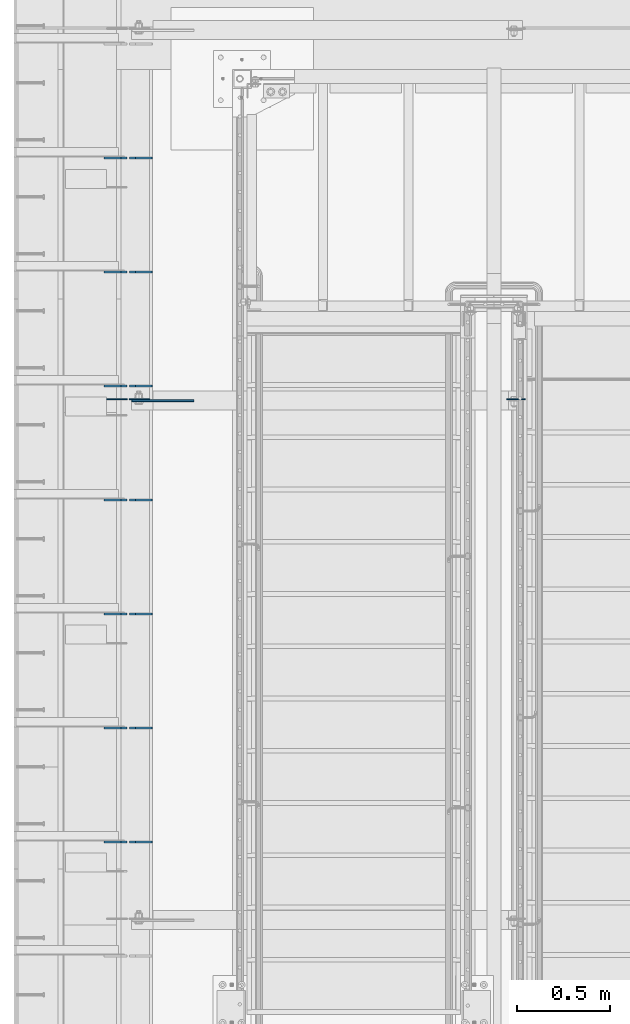
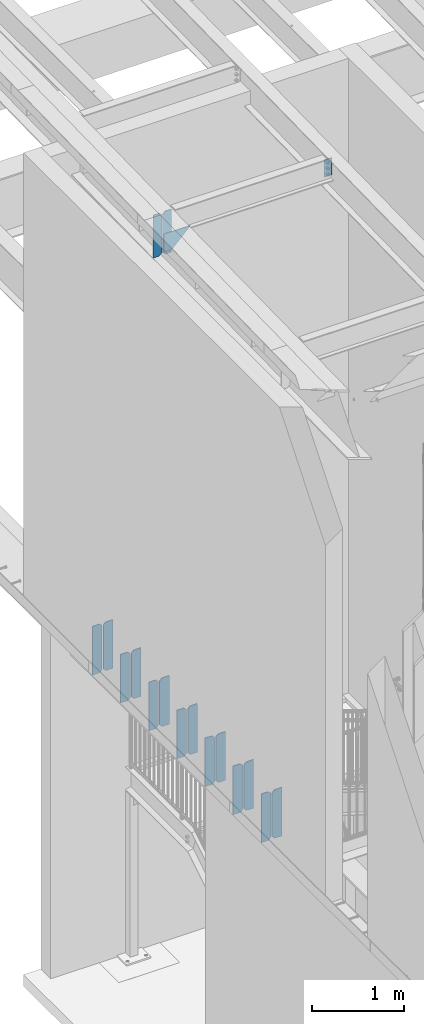
# One storey, part 1512 of 1763: 18 plates, 4 elements without a shape of their own.
"""IFC2X3 building model written with IfcOpenShell, lengths in millimetres."""

from ifc_helpers import new_model, si_unit, frame, origin_with_axes, place, context, subcontext, project, spatial, faceted_brep, material, type_object, element, aggregate, save


model = new_model("IFC2X3")

# Units and contexts
model_context = context("Model", 3, precision=1e-05, world=origin_with_axes())
body_context = subcontext(model_context, "Body", "Model", "MODEL_VIEW")
ifc_project = project(units=[si_unit("LENGTHUNIT", "METRE", prefix="MILLI"), si_unit("AREAUNIT", "SQUARE_METRE"), si_unit("VOLUMEUNIT", "CUBIC_METRE"), si_unit("MASSUNIT", "GRAM", prefix="KILO"), si_unit("TIMEUNIT", "SECOND"), si_unit("PLANEANGLEUNIT", "RADIAN"), si_unit("SOLIDANGLEUNIT", "STERADIAN"), si_unit("THERMODYNAMICTEMPERATUREUNIT", "DEGREE_CELSIUS"), si_unit("LUMINOUSINTENSITYUNIT", "LUMEN")], contexts=[model_context])

# Site, building, storey
site_placement = place(None, origin_with_axes())
site = spatial("IfcSite", under=ifc_project, at=site_placement, CompositionType="ELEMENT")
building_placement = place(site_placement, origin_with_axes())
building = spatial("IfcBuilding", under=site, at=building_placement, Name="Undefined", CompositionType="ELEMENT")
storey_placement = place(building_placement, origin_with_axes())
storey = spatial("IfcBuildingStorey", under=building, at=storey_placement, Name="Undefined", CompositionType="ELEMENT", Elevation=0.0)

# Assembly, plates
assembly_1_placement = place(storey_placement, origin_with_axes())
assembly_1 = element("IfcElementAssembly", 1, at=assembly_1_placement, inside=storey, Name="BEAM", AssemblyPlace="NOTDEFINED", PredefinedType="RIGID_FRAME")
ifc_material = material(Name="STEEL/A36")
plate_type_1 = type_object("IfcPlateType", PredefinedType="NOTDEFINED")
plate_1_placement = place(assembly_1_placement, frame((-87246.8497736984, 33218.4375, 4525.9625), z_axis=(0.0, 0.0, 1.0), x_axis=(-1.0, 0.0, 0.0)))
plate_1 = element("IfcPlate", 2, at=plate_1_placement, type_object=plate_type_1, material=ifc_material, Name="PLATE", context=body_context, shape_type="Brep", body=[
    faceted_brep([(0.0, -4.76249999999982, 0.0), (0.0, -4.76250000000073, 644.525024414062), (0.0, 4.76250000000073, 644.525024414062), (0.0, 4.76249999999982, 0.0), (89.6937484741211, -4.76250000000073, 644.525024414062), (89.6937484741211, 4.76250000000073, 644.525024414062), (121.443748474121, -4.76250000000073, 612.775024414062), (121.443748474121, 4.76250000000073, 612.775024414062), (121.443748474121, -4.76250000000073, 31.75), (121.443748474121, 4.76250000000073, 31.75), (89.6937484741211, -4.76249999999709, 0.0), (89.6937484741211, 4.76249999999709, 0.0)], [[[0, 1, 2, 3]], [[1, 4, 5, 2]], [[4, 6, 7, 5]], [[6, 8, 9, 7]], [[8, 10, 11, 9]], [[10, 0, 3, 11]], [[5, 7, 9, 11, 3, 2]], [[10, 8, 6, 4, 1, 0]]]),
])
plate_2_placement = place(assembly_1_placement, frame((-87382.5810236984, 33218.4375, 4525.9625), z_axis=(0.0, 0.0, 1.0), x_axis=(-1.0, 0.0, 0.0)))
plate_2 = element("IfcPlate", 3, at=plate_2_placement, type_object=plate_type_1, material=ifc_material, Name="PLATE", context=body_context, shape_type="Brep", body=[
    faceted_brep([(0.0, -4.76250000000073, 31.75), (0.0, -4.76250000000073, 612.775024414062), (0.0, 4.76250000000073, 612.775024414062), (0.0, 4.76250000000073, 31.75), (31.75, -4.76250000000073, 644.525024414062), (31.75, 4.76250000000073, 644.525024414062), (121.443748474121, -4.76250000000073, 644.525024414062), (121.443748474121, 4.76250000000073, 644.525024414062), (121.443748474121, -4.76250000000073, 0.0), (121.443748474121, 4.76250000000073, 0.0), (31.75, -4.76250000000073, 0.0), (31.75, 4.76250000000073, 0.0)], [[[0, 1, 2, 3]], [[1, 4, 5, 2]], [[4, 6, 7, 5]], [[6, 8, 9, 7]], [[8, 10, 11, 9]], [[10, 0, 3, 11]], [[5, 7, 9, 11, 3, 2]], [[10, 8, 6, 4, 1, 0]]]),
])
plate_3_placement = place(assembly_1_placement, frame((-87246.8497736984, 33828.0375, 4525.9625), z_axis=(0.0, 0.0, 1.0), x_axis=(-1.0, 0.0, 0.0)))
plate_3 = element("IfcPlate", 4, at=plate_3_placement, type_object=plate_type_1, material=ifc_material, Name="PLATE", context=body_context, shape_type="Brep", body=[
    faceted_brep([(0.0, -4.76249999999982, 0.0), (0.0, -4.76250000000073, 644.525024414062), (0.0, 4.76250000000073, 644.525024414062), (0.0, 4.76249999999982, 0.0), (89.6937484741211, -4.76250000000073, 644.525024414062), (89.6937484741211, 4.76250000000073, 644.525024414062), (121.443748474121, -4.76250000000073, 612.775024414062), (121.443748474121, 4.76250000000073, 612.775024414062), (121.443748474121, -4.76250000000073, 31.75), (121.443748474121, 4.76250000000073, 31.75), (89.6937484741211, -4.76249999999709, 0.0), (89.6937484741211, 4.76249999999709, 0.0)], [[[0, 1, 2, 3]], [[1, 4, 5, 2]], [[4, 6, 7, 5]], [[6, 8, 9, 7]], [[8, 10, 11, 9]], [[10, 0, 3, 11]], [[5, 7, 9, 11, 3, 2]], [[10, 8, 6, 4, 1, 0]]]),
])
plate_4_placement = place(assembly_1_placement, frame((-87382.5810236984, 33828.0375, 4525.9625), z_axis=(0.0, 0.0, 1.0), x_axis=(-1.0, 0.0, 0.0)))
plate_4 = element("IfcPlate", 5, at=plate_4_placement, type_object=plate_type_1, material=ifc_material, Name="PLATE", context=body_context, shape_type="Brep", body=[
    faceted_brep([(0.0, -4.76250000000073, 31.75), (0.0, -4.76250000000073, 612.775024414062), (0.0, 4.76250000000073, 612.775024414062), (0.0, 4.76250000000073, 31.75), (31.75, -4.76250000000073, 644.525024414062), (31.75, 4.76250000000073, 644.525024414062), (121.443748474121, -4.76250000000073, 644.525024414062), (121.443748474121, 4.76250000000073, 644.525024414062), (121.443748474121, -4.76250000000073, 0.0), (121.443748474121, 4.76250000000073, 0.0), (31.75, -4.76250000000073, 0.0), (31.75, 4.76250000000073, 0.0)], [[[0, 1, 2, 3]], [[1, 4, 5, 2]], [[4, 6, 7, 5]], [[6, 8, 9, 7]], [[8, 10, 11, 9]], [[10, 0, 3, 11]], [[5, 7, 9, 11, 3, 2]], [[10, 8, 6, 4, 1, 0]]]),
])
plate_5_placement = place(assembly_1_placement, frame((-87246.8497736984, 34437.6375, 4525.9625), z_axis=(0.0, 0.0, 1.0), x_axis=(-1.0, 0.0, 0.0)))
plate_5 = element("IfcPlate", 6, at=plate_5_placement, type_object=plate_type_1, material=ifc_material, Name="PLATE", context=body_context, shape_type="Brep", body=[
    faceted_brep([(0.0, -4.76249999999982, 0.0), (0.0, -4.76250000000073, 644.525024414062), (0.0, 4.76250000000073, 644.525024414062), (0.0, 4.76249999999982, 0.0), (89.6937484741211, -4.76250000000073, 644.525024414062), (89.6937484741211, 4.76250000000073, 644.525024414062), (121.443748474121, -4.76250000000073, 612.775024414062), (121.443748474121, 4.76250000000073, 612.775024414062), (121.443748474121, -4.76250000000073, 31.75), (121.443748474121, 4.76250000000073, 31.75), (89.6937484741211, -4.76249999999709, 0.0), (89.6937484741211, 4.76249999999709, 0.0)], [[[0, 1, 2, 3]], [[1, 4, 5, 2]], [[4, 6, 7, 5]], [[6, 8, 9, 7]], [[8, 10, 11, 9]], [[10, 0, 3, 11]], [[5, 7, 9, 11, 3, 2]], [[10, 8, 6, 4, 1, 0]]]),
])
plate_6_placement = place(assembly_1_placement, frame((-87382.5810236984, 34437.6375, 4525.9625), z_axis=(0.0, 0.0, 1.0), x_axis=(-1.0, 0.0, 0.0)))
plate_6 = element("IfcPlate", 7, at=plate_6_placement, type_object=plate_type_1, material=ifc_material, Name="PLATE", context=body_context, shape_type="Brep", body=[
    faceted_brep([(0.0, -4.76250000000073, 31.75), (0.0, -4.76250000000073, 612.775024414062), (0.0, 4.76250000000073, 612.775024414062), (0.0, 4.76250000000073, 31.75), (31.75, -4.76250000000073, 644.525024414062), (31.75, 4.76250000000073, 644.525024414062), (121.443748474121, -4.76250000000073, 644.525024414062), (121.443748474121, 4.76250000000073, 644.525024414062), (121.443748474121, -4.76250000000073, 0.0), (121.443748474121, 4.76250000000073, 0.0), (31.75, -4.76250000000073, 0.0), (31.75, 4.76250000000073, 0.0)], [[[0, 1, 2, 3]], [[1, 4, 5, 2]], [[4, 6, 7, 5]], [[6, 8, 9, 7]], [[8, 10, 11, 9]], [[10, 0, 3, 11]], [[5, 7, 9, 11, 3, 2]], [[10, 8, 6, 4, 1, 0]]]),
])
plate_7_placement = place(assembly_1_placement, frame((-87246.8497736984, 35047.2375, 4525.9625), z_axis=(0.0, 0.0, 1.0), x_axis=(-1.0, 0.0, 0.0)))
plate_7 = element("IfcPlate", 8, at=plate_7_placement, type_object=plate_type_1, material=ifc_material, Name="PLATE", context=body_context, shape_type="Brep", body=[
    faceted_brep([(0.0, -4.76249999999982, 0.0), (0.0, -4.76250000000073, 644.525024414062), (0.0, 4.76250000000073, 644.525024414062), (0.0, 4.76249999999982, 0.0), (89.6937484741211, -4.76250000000073, 644.525024414062), (89.6937484741211, 4.76250000000073, 644.525024414062), (121.443748474121, -4.76250000000073, 612.775024414062), (121.443748474121, 4.76250000000073, 612.775024414062), (121.443748474121, -4.76250000000073, 31.75), (121.443748474121, 4.76250000000073, 31.75), (89.6937484741211, -4.76249999999709, 0.0), (89.6937484741211, 4.76249999999709, 0.0)], [[[0, 1, 2, 3]], [[1, 4, 5, 2]], [[4, 6, 7, 5]], [[6, 8, 9, 7]], [[8, 10, 11, 9]], [[10, 0, 3, 11]], [[5, 7, 9, 11, 3, 2]], [[10, 8, 6, 4, 1, 0]]]),
])
plate_8_placement = place(assembly_1_placement, frame((-87382.5810236984, 35047.2375, 4525.9625), z_axis=(0.0, 0.0, 1.0), x_axis=(-1.0, 0.0, 0.0)))
plate_8 = element("IfcPlate", 9, at=plate_8_placement, type_object=plate_type_1, material=ifc_material, Name="PLATE", context=body_context, shape_type="Brep", body=[
    faceted_brep([(0.0, -4.76250000000073, 31.75), (0.0, -4.76250000000073, 612.775024414062), (0.0, 4.76250000000073, 612.775024414062), (0.0, 4.76250000000073, 31.75), (31.75, -4.76250000000073, 644.525024414062), (31.75, 4.76250000000073, 644.525024414062), (121.443748474121, -4.76250000000073, 644.525024414062), (121.443748474121, 4.76250000000073, 644.525024414062), (121.443748474121, -4.76250000000073, 0.0), (121.443748474121, 4.76250000000073, 0.0), (31.75, -4.76250000000073, 0.0), (31.75, 4.76250000000073, 0.0)], [[[0, 1, 2, 3]], [[1, 4, 5, 2]], [[4, 6, 7, 5]], [[6, 8, 9, 7]], [[8, 10, 11, 9]], [[10, 0, 3, 11]], [[5, 7, 9, 11, 3, 2]], [[10, 8, 6, 4, 1, 0]]]),
])
plate_9_placement = place(assembly_1_placement, frame((-87246.8497736984, 35656.8375, 4525.9625), z_axis=(0.0, 0.0, 1.0), x_axis=(-1.0, 0.0, 0.0)))
plate_9 = element("IfcPlate", 10, at=plate_9_placement, type_object=plate_type_1, material=ifc_material, Name="PLATE", context=body_context, shape_type="Brep", body=[
    faceted_brep([(0.0, -4.76249999999982, 0.0), (0.0, -4.76250000000073, 644.525024414062), (0.0, 4.76250000000073, 644.525024414062), (0.0, 4.76249999999982, 0.0), (89.6937484741211, -4.76250000000073, 644.525024414062), (89.6937484741211, 4.76250000000073, 644.525024414062), (121.443748474121, -4.76250000000073, 612.775024414062), (121.443748474121, 4.76250000000073, 612.775024414062), (121.443748474121, -4.76250000000073, 31.75), (121.443748474121, 4.76250000000073, 31.75), (89.6937484741211, -4.76249999999709, 0.0), (89.6937484741211, 4.76249999999709, 0.0)], [[[0, 1, 2, 3]], [[1, 4, 5, 2]], [[4, 6, 7, 5]], [[6, 8, 9, 7]], [[8, 10, 11, 9]], [[10, 0, 3, 11]], [[5, 7, 9, 11, 3, 2]], [[10, 8, 6, 4, 1, 0]]]),
])
plate_10_placement = place(assembly_1_placement, frame((-87382.5810236984, 35656.8375, 4525.9625), z_axis=(0.0, 0.0, 1.0), x_axis=(-1.0, 0.0, 0.0)))
plate_10 = element("IfcPlate", 11, at=plate_10_placement, type_object=plate_type_1, material=ifc_material, Name="PLATE", context=body_context, shape_type="Brep", body=[
    faceted_brep([(0.0, -4.76250000000073, 31.75), (0.0, -4.76250000000073, 612.775024414062), (0.0, 4.76250000000073, 612.775024414062), (0.0, 4.76250000000073, 31.75), (31.75, -4.76250000000073, 644.525024414062), (31.75, 4.76250000000073, 644.525024414062), (121.443748474121, -4.76250000000073, 644.525024414062), (121.443748474121, 4.76250000000073, 644.525024414062), (121.443748474121, -4.76250000000073, 0.0), (121.443748474121, 4.76250000000073, 0.0), (31.75, -4.76250000000073, 0.0), (31.75, 4.76250000000073, 0.0)], [[[0, 1, 2, 3]], [[1, 4, 5, 2]], [[4, 6, 7, 5]], [[6, 8, 9, 7]], [[8, 10, 11, 9]], [[10, 0, 3, 11]], [[5, 7, 9, 11, 3, 2]], [[10, 8, 6, 4, 1, 0]]]),
])
plate_11_placement = place(assembly_1_placement, frame((-87246.8497736984, 36266.4375, 4525.9625), z_axis=(0.0, 0.0, 1.0), x_axis=(-1.0, 0.0, 0.0)))
plate_11 = element("IfcPlate", 12, at=plate_11_placement, type_object=plate_type_1, material=ifc_material, Name="PLATE", context=body_context, shape_type="Brep", body=[
    faceted_brep([(0.0, -4.76249999999982, 0.0), (0.0, -4.76250000000073, 644.525024414062), (0.0, 4.76250000000073, 644.525024414062), (0.0, 4.76249999999982, 0.0), (89.6937484741211, -4.76250000000073, 644.525024414062), (89.6937484741211, 4.76250000000073, 644.525024414062), (121.443748474121, -4.76250000000073, 612.775024414062), (121.443748474121, 4.76250000000073, 612.775024414062), (121.443748474121, -4.76250000000073, 31.75), (121.443748474121, 4.76250000000073, 31.75), (89.6937484741211, -4.76249999999709, 0.0), (89.6937484741211, 4.76249999999709, 0.0)], [[[0, 1, 2, 3]], [[1, 4, 5, 2]], [[4, 6, 7, 5]], [[6, 8, 9, 7]], [[8, 10, 11, 9]], [[10, 0, 3, 11]], [[5, 7, 9, 11, 3, 2]], [[10, 8, 6, 4, 1, 0]]]),
])
plate_12_placement = place(assembly_1_placement, frame((-87382.5810236984, 36266.4375, 4525.9625), z_axis=(0.0, 0.0, 1.0), x_axis=(-1.0, 0.0, 0.0)))
plate_12 = element("IfcPlate", 13, at=plate_12_placement, type_object=plate_type_1, material=ifc_material, Name="PLATE", context=body_context, shape_type="Brep", body=[
    faceted_brep([(0.0, -4.76250000000073, 31.75), (0.0, -4.76250000000073, 612.775024414062), (0.0, 4.76250000000073, 612.775024414062), (0.0, 4.76250000000073, 31.75), (31.75, -4.76250000000073, 644.525024414062), (31.75, 4.76250000000073, 644.525024414062), (121.443748474121, -4.76250000000073, 644.525024414062), (121.443748474121, 4.76250000000073, 644.525024414062), (121.443748474121, -4.76250000000073, 0.0), (121.443748474121, 4.76250000000073, 0.0), (31.75, -4.76250000000073, 0.0), (31.75, 4.76250000000073, 0.0)], [[[0, 1, 2, 3]], [[1, 4, 5, 2]], [[4, 6, 7, 5]], [[6, 8, 9, 7]], [[8, 10, 11, 9]], [[10, 0, 3, 11]], [[5, 7, 9, 11, 3, 2]], [[10, 8, 6, 4, 1, 0]]]),
])
plate_13_placement = place(assembly_1_placement, frame((-87246.8497736984, 36876.0375, 4525.9625), z_axis=(0.0, 0.0, 1.0), x_axis=(-1.0, 0.0, 0.0)))
plate_13 = element("IfcPlate", 14, at=plate_13_placement, type_object=plate_type_1, material=ifc_material, Name="PLATE", context=body_context, shape_type="Brep", body=[
    faceted_brep([(0.0, -4.76249999999982, 0.0), (0.0, -4.76250000000073, 644.525024414062), (0.0, 4.76250000000073, 644.525024414062), (0.0, 4.76249999999982, 0.0), (89.6937484741211, -4.76250000000073, 644.525024414062), (89.6937484741211, 4.76250000000073, 644.525024414062), (121.443748474121, -4.76250000000073, 612.775024414062), (121.443748474121, 4.76250000000073, 612.775024414062), (121.443748474121, -4.76250000000073, 31.75), (121.443748474121, 4.76250000000073, 31.75), (89.6937484741211, -4.76249999999709, 0.0), (89.6937484741211, 4.76249999999709, 0.0)], [[[0, 1, 2, 3]], [[1, 4, 5, 2]], [[4, 6, 7, 5]], [[6, 8, 9, 7]], [[8, 10, 11, 9]], [[10, 0, 3, 11]], [[5, 7, 9, 11, 3, 2]], [[10, 8, 6, 4, 1, 0]]]),
])
plate_14_placement = place(assembly_1_placement, frame((-87382.5810236984, 36876.0375, 4525.9625), z_axis=(0.0, 0.0, 1.0), x_axis=(-1.0, 0.0, 0.0)))
plate_14 = element("IfcPlate", 15, at=plate_14_placement, type_object=plate_type_1, material=ifc_material, Name="PLATE", context=body_context, shape_type="Brep", body=[
    faceted_brep([(0.0, -4.76250000000073, 31.75), (0.0, -4.76250000000073, 612.775024414062), (0.0, 4.76250000000073, 612.775024414062), (0.0, 4.76250000000073, 31.75), (31.75, -4.76250000000073, 644.525024414062), (31.75, 4.76250000000073, 644.525024414062), (121.443748474121, -4.76250000000073, 644.525024414062), (121.443748474121, 4.76250000000073, 644.525024414062), (121.443748474121, -4.76250000000073, 0.0), (121.443748474121, 4.76250000000073, 0.0), (31.75, -4.76250000000073, 0.0), (31.75, 4.76250000000073, 0.0)], [[[0, 1, 2, 3]], [[1, 4, 5, 2]], [[4, 6, 7, 5]], [[6, 8, 9, 7]], [[8, 10, 11, 9]], [[10, 0, 3, 11]], [[5, 7, 9, 11, 3, 2]], [[10, 8, 6, 4, 1, 0]]]),
])
aggregate(assembly_1, [plate_1, plate_2, plate_3, plate_4, plate_5, plate_6, plate_7, plate_8, plate_9, plate_10, plate_11, plate_12, plate_13, plate_14])

# Assembly, plate
assembly_2_placement = place(storey_placement, origin_with_axes())
assembly_2 = element("IfcElementAssembly", 16, at=assembly_2_placement, inside=storey, Name="BEAM", AssemblyPlace="NOTDEFINED", PredefinedType="RIGID_FRAME")
plate_type_2 = type_object("IfcPlateType", PredefinedType="NOTDEFINED")
plate_15_placement = place(assembly_2_placement, frame((-85253.0631665555, 35585.3999999917, 11367.1568944727), z_axis=(-1.0, 0.0, 0.0), x_axis=(0.0, 0.0, -1.0)))
plate_15 = element("IfcPlate", 17, at=plate_15_placement, type_object=plate_type_2, material=ifc_material, Name="PLATE", context=body_context, shape_type="Brep", body=[
    faceted_brep([(1.81898940354586e-12, -3.17500000000291, 0.0), (-2.52839527092874e-10, -3.17500000000001, 98.4250000002357), (4.17785486206412e-08, 3.17500000000001, 98.425000000243), (-1.81898940354586e-12, 3.17499999997381, 0.0), (228.600006103516, -3.17499999999927, 98.4250030517578), (228.600006103516, 3.17499999999927, 98.4250030517578), (228.600006103516, -3.17500000001019, -7.27595761418343e-12), (228.600006103516, 3.17499999999563, -7.27595761418343e-12)], [[[0, 1, 2, 3]], [[1, 4, 5, 2]], [[4, 6, 7, 5]], [[6, 0, 3, 7]], [[5, 7, 3, 2]], [[6, 4, 1, 0]]]),
])
aggregate(assembly_2, [plate_15])

assembly_3_placement = place(storey_placement, origin_with_axes())
assembly_3 = element("IfcElementAssembly", 18, at=assembly_3_placement, inside=storey, Name="BEAM", AssemblyPlace="NOTDEFINED", PredefinedType="RIGID_FRAME")
plate_type_3 = type_object("IfcPlateType", PredefinedType="NOTDEFINED")
plate_16_placement = place(assembly_3_placement, frame((-87260.0435256352, 35577.4625080741, 10857.9732655736), z_axis=(-0.707106781186552, 0.0, 0.707106781186543), x_axis=(0.707106781186542, 0.0, 0.707106781186553)))
plate_16 = element("IfcPlate", 19, at=plate_16_placement, type_object=plate_type_3, material=ifc_material, Name="PLATE", context=body_context, shape_type="Brep", body=[
    faceted_brep([(0.0, -4.76249999999982, 0.0), (-68.6865768438074, -4.76249999999709, 68.6865844732238), (-68.6865768438074, 4.76249999999709, 68.6865844732238), (0.0, 4.76249999999982, 0.0), (98.2851104731089, -4.76249999999709, 235.658279419542), (98.2851104731089, 4.76249999999709, 235.658279419542), (333.943389893917, -4.76249999999709, -3.92901711165905e-10), (333.943389893917, 4.76249999999709, -3.92901711165905e-10)], [[[0, 1, 2, 3]], [[1, 4, 5, 2]], [[4, 6, 7, 5]], [[6, 0, 3, 7]], [[5, 7, 3, 2]], [[6, 4, 1, 0]]]),
])
aggregate(assembly_3, [plate_16])

# Assembly, plates
assembly_4_placement = place(storey_placement, origin_with_axes())
assembly_4 = element("IfcElementAssembly", 20, at=assembly_4_placement, inside=storey, Name="BEAM", AssemblyPlace="NOTDEFINED", PredefinedType="RIGID_FRAME")
plate_type_4 = type_object("IfcPlateType", PredefinedType="NOTDEFINED")
plate_17_placement = place(assembly_4_placement, frame((-87381.2935236983, 35585.3999999265, 10818.2529207425), z_axis=(0.0, 0.0, 1.0), x_axis=(-1.0, 0.0, 0.0)))
plate_17 = element("IfcPlate", 21, at=plate_17_placement, type_object=plate_type_4, material=ifc_material, Name="PLATE", context=body_context, shape_type="Brep", body=[
    faceted_brep([(0.0, -3.17500000000291, 31.75), (0.0, -3.17500000000291, 535.965942382812), (0.0, 3.17500000000291, 535.965942382812), (0.0, 3.17500000000291, 31.75), (31.75, -3.17500000000291, 567.715942382812), (31.75, 3.17500000000291, 567.715942382812), (108.743751525879, -3.17500000000291, 567.715942382812), (108.743751525879, 3.17500000000291, 567.715942382812), (108.743751525879, -3.17500000000291, 0.0), (108.743751525879, 3.17500000000291, 0.0), (31.7499999999036, -3.17499999997381, 9.42916855706244e-11), (31.7499999998854, 3.17500000000291, 9.42916855706244e-11)], [[[0, 1, 2, 3]], [[1, 4, 5, 2]], [[4, 6, 7, 5]], [[6, 8, 9, 7]], [[8, 10, 11, 9]], [[10, 0, 3, 11]], [[5, 7, 9, 11, 3, 2]], [[10, 8, 6, 4, 1, 0]]]),
])
plate_18_placement = place(assembly_4_placement, frame((-87369.5810236984, 35585.4000000436, 10818.2529207449), z_axis=(0.0, 0.0, 1.0), x_axis=(1.0, 0.0, 0.0)))
plate_18 = element("IfcPlate", 22, at=plate_18_placement, type_object=plate_type_4, material=ifc_material, Name="PLATE", context=body_context, shape_type="Brep", body=[
    faceted_brep([(0.0, -3.17500000000291, 31.75), (0.0, -3.17500000000291, 537.553405761719), (0.0, 3.17500000000291, 537.553405761719), (0.0, 3.17500000000291, 31.75), (31.75, -3.17500000000291, 569.303405761719), (31.75, 3.17500000000291, 569.303405761719), (109.537498474121, -3.17500000000291, 569.303405761719), (109.537498474121, 3.17500000000291, 569.303405761719), (109.537498474121, -3.17500000000291, 0.0), (109.537498474121, 3.17500000000291, 0.0), (31.7499999999036, -3.17499999997381, 9.42916855706244e-11), (31.7499999998854, 3.17500000000291, 9.42916855706244e-11)], [[[0, 1, 2, 3]], [[1, 4, 5, 2]], [[4, 6, 7, 5]], [[6, 8, 9, 7]], [[8, 10, 11, 9]], [[10, 0, 3, 11]], [[5, 7, 9, 11, 3, 2]], [[10, 8, 6, 4, 1, 0]]]),
])
aggregate(assembly_4, [plate_17, plate_18])

save(model, "model.ifc")
